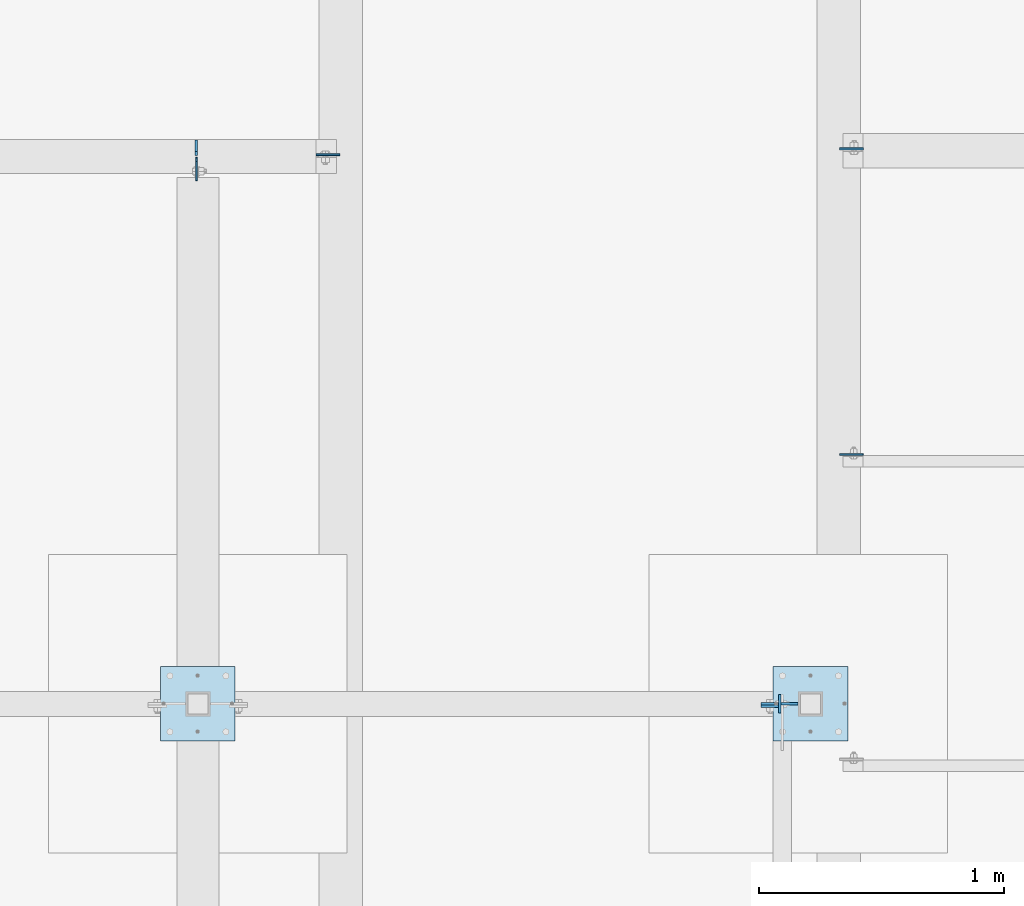
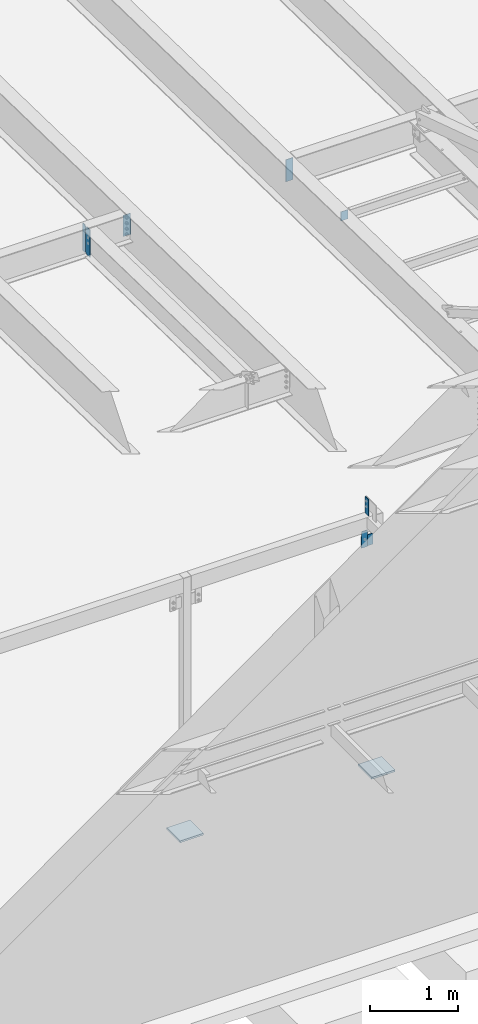
# One storey, part 1473 of 1763: 10 plates, 6 elements without a shape of their own.
"""IFC2X3 building model written with IfcOpenShell, lengths in millimetres."""

import ifcopenshell
import ifcopenshell.guid

model = None  # the IFC model being written
_history = None  # IfcOwnerHistory: only IFC2X3 demands one
_inside = {}  # id of a spatial element -> (the spatial element, [elements in it])
_under = {}  # id of a project, library or spatial element -> (it, [spatial elements below it])
_declared = {}  # id of a project -> (the project, [libraries it declares])
_typed = {}  # id of a type object -> (the type object, [elements of that type])
_made_of = {}  # id of a material, layer set ... -> (it, [elements and type objects made of it])


def new_model(schema):
    """Start an empty IFC model of exactly this schema.

    Asked for "IFC4X3", IfcOpenShell would pick the latest addendum, in which some entities
    have other attributes; the version numbers below select the first issue.
    IFC2X3 requires an IfcOwnerHistory on every rooted entity: one is made here for all.
    """
    global model, _history
    if schema == "IFC4X3":
        model = ifcopenshell.file(schema_version=(4, 3, 0, 0))
    else:
        model = ifcopenshell.file(schema=schema)
    _inside.clear()
    _under.clear()
    _declared.clear()
    _typed.clear()
    _made_of.clear()
    _history = None
    if model.schema == "IFC2X3":
        org = make("IfcOrganization", Name="unknown")
        user = make(
            "IfcPersonAndOrganization",
            ThePerson=make("IfcPerson", FamilyName="unknown"),
            TheOrganization=org,
        )
        app = make(
            "IfcApplication",
            ApplicationDeveloper=org,
            Version="unknown",
            ApplicationFullName="unknown",
            ApplicationIdentifier="unknown",
        )
        _history = make(
            "IfcOwnerHistory",
            OwningUser=user,
            OwningApplication=app,
            ChangeAction="ADDED",
            CreationDate=0,
        )
    return model


def make(cls, **values):
    """One entity of the class cls with the attributes given. An attribute that is None is left unset."""
    return model.create_entity(
        cls, **{name: value for name, value in values.items() if value is not None}
    )


def rooted(cls, **values):
    """An entity with a GlobalId (a new one), such as an element, a storey or a relation."""
    return make(cls, GlobalId=ifcopenshell.guid.new(), OwnerHistory=_history, **values)


def si_unit(unit_type, name, prefix=None):
    """IfcSIUnit, for example si_unit("LENGTHUNIT", "METRE", prefix="MILLI")."""
    return make("IfcSIUnit", UnitType=unit_type, Prefix=prefix, Name=name)


def assignment(units):
    """IfcUnitAssignment: the units of a project."""
    return None if units is None else make("IfcUnitAssignment", Units=units)


def point(xyz):
    """IfcCartesianPoint."""
    return None if xyz is None else make("IfcCartesianPoint", Coordinates=xyz)


def direction(xyz):
    """IfcDirection."""
    return None if xyz is None else make("IfcDirection", DirectionRatios=xyz)


def frame(location, z_axis=None, x_axis=None):
    """IfcAxis2Placement3D, a coordinate frame: its origin and axes. An axis left out is left unset."""
    return make(
        "IfcAxis2Placement3D",
        Location=point(location),
        Axis=direction(z_axis),
        RefDirection=direction(x_axis),
    )


def origin_with_axes():
    """The frame at (0, 0, 0) with the z axis (0, 0, 1) and the x axis (1, 0, 0) written out."""
    return frame((0.0, 0.0, 0.0), z_axis=(0.0, 0.0, 1.0), x_axis=(1.0, 0.0, 0.0))


def place(relative_to, where):
    """IfcLocalPlacement: puts the frame where relative to a parent placement (None: the world)."""
    return make(
        "IfcLocalPlacement", PlacementRelTo=relative_to, RelativePlacement=where
    )


def context(
    kind, dimensions, precision=None, world=None, true_north=None, identifier=None
):
    """IfcGeometricRepresentationContext, for example the 3D "Model" context."""
    return make(
        "IfcGeometricRepresentationContext",
        ContextIdentifier=identifier,
        ContextType=kind,
        CoordinateSpaceDimension=dimensions,
        Precision=precision,
        WorldCoordinateSystem=world,
        TrueNorth=true_north,
    )


def subcontext(parent, identifier, kind, view, scale=None):
    """IfcGeometricRepresentationSubContext, for example "Body" below "Model"."""
    return make(
        "IfcGeometricRepresentationSubContext",
        ContextIdentifier=identifier,
        ContextType=kind,
        ParentContext=parent,
        TargetScale=scale,
        TargetView=view,
    )


def project(units=None, contexts=None):
    """IfcProject with its units and contexts."""
    return rooted(
        "IfcProject",
        Name="project",
        RepresentationContexts=contexts,
        UnitsInContext=assignment(units),
    )


def spatial(cls, under=None, at=None, **own):
    """A site, building, storey or space (cls), placed at a placement, below another one or the project."""
    s = rooted(cls, ObjectPlacement=at, **own)
    if under is not None:
        _under.setdefault(under.id(), (under, []))[1].append(s)
    return s


def faces_of(points, faces, orient=None, outer=None):
    """IfcFace entities. A face is a list of loops; a loop is a list of indices into points, from 0.

    orient and outer hold one flag for each loop. By default every Orientation is true, the
    first loop of a face is its IfcFaceOuterBound and the others are IfcFaceBound.
    """
    made = []
    for i, loops in enumerate(faces):
        bounds = []
        for j, loop in enumerate(loops):
            is_outer = j == 0 if outer is None else outer[i][j]
            bounds.append(
                make(
                    "IfcFaceOuterBound" if is_outer else "IfcFaceBound",
                    Bound=make("IfcPolyLoop", Polygon=[points[k] for k in loop]),
                    Orientation=True if orient is None else orient[i][j],
                )
            )
        made.append(make("IfcFace", Bounds=bounds))
    return made


def faceted_brep(points, faces, orient=None, outer=None, voids=None):
    """IfcFacetedBrep: a solid bounded by flat faces; with voids (closed shells), ...WithVoids."""
    shared = [point(p) for p in points]
    hull = make("IfcClosedShell", CfsFaces=faces_of(shared, faces, orient, outer))
    if voids is None:
        return make("IfcFacetedBrep", Outer=hull)
    return make(
        "IfcFacetedBrepWithVoids",
        Outer=hull,
        Voids=[
            make(cls, CfsFaces=faces_of(shared, fs, o, b)) for cls, fs, o, b in voids
        ],
    )


def shape(context_of_items, identifier, shape_type, items):
    """IfcShapeRepresentation: the items that make up one representation, for example the "Body"."""
    return make(
        "IfcShapeRepresentation",
        ContextOfItems=context_of_items,
        RepresentationIdentifier=identifier,
        RepresentationType=shape_type,
        Items=items,
    )


def material(Name=None, Category=None):
    """IfcMaterial."""
    return make("IfcMaterial", Name=Name, Category=Category)


def made_of(thing, what):
    """Note that an element or type object is made of a material, layer set ...; save() writes the relation."""
    if what is not None:
        _made_of.setdefault(what.id(), (what, []))[1].append(thing)
    return thing


def type_object(cls, material=None, **own):
    """A type object (cls), such as IfcWallType, which elements share."""
    return made_of(rooted(cls, **own), material)


def element(
    cls,
    number,
    at=None,
    inside=None,
    cuts=None,
    type_object=None,
    material=None,
    context=None,
    identifier="Body",
    shape_type=None,
    held_by="IfcProductDefinitionShape",
    body=None,
    shapes=None,
    **own,
):
    """One element of the class cls, such as IfcWall. Its Tag is "e" and its number.

    at: its placement. inside: the storey or other place that contains it. cuts: it is an
    opening in that element (IfcRelVoidsElement). A single representation is given by context,
    identifier, shape_type and body (its items); several are given by shapes. held_by: the class
    of the entity that holds the representations. save() writes the other relations.
    """
    e = rooted(cls, Tag="e%d" % number, ObjectPlacement=at, **own)
    if body is not None:
        shapes = [shape(context, identifier, shape_type, body)]
    if shapes is not None:
        e.Representation = make(held_by, Representations=shapes)
    if inside is not None:
        _inside.setdefault(inside.id(), (inside, []))[1].append(e)
    if cuts is not None:
        rooted(
            "IfcRelVoidsElement", RelatingBuildingElement=cuts, RelatedOpeningElement=e
        )
    if type_object is not None:
        _typed.setdefault(type_object.id(), (type_object, []))[1].append(e)
    return made_of(e, material)


def aggregate(whole, parts):
    """IfcRelAggregates: a whole, such as a stair, and the parts it consists of."""
    return rooted("IfcRelAggregates", RelatingObject=whole, RelatedObjects=parts)


def save(model, path):
    """Write the relations noted so far, then the file.

    IfcRelAggregates (storeys below a building ...), IfcRelContainedInSpatialStructure (elements
    in a storey), IfcRelDefinesByType, IfcRelAssociatesMaterial and IfcRelDeclares: one each for
    every whole, place, type object, material and project.
    """
    for whole, parts in _under.values():
        aggregate(whole, parts)
    for where, things in _inside.values():
        rooted(
            "IfcRelContainedInSpatialStructure",
            RelatedElements=things,
            RelatingStructure=where,
        )
    for kind, things in _typed.values():
        rooted("IfcRelDefinesByType", RelatedObjects=things, RelatingType=kind)
    for what, things in _made_of.values():
        rooted("IfcRelAssociatesMaterial", RelatedObjects=things, RelatingMaterial=what)
    for by, libraries in _declared.values():
        rooted("IfcRelDeclares", RelatingContext=by, RelatedDefinitions=libraries)
    model.write(path)


model = new_model("IFC2X3")

# Units and contexts
model_context = context("Model", 3, precision=1e-05, world=origin_with_axes())
body_context = subcontext(model_context, "Body", "Model", "MODEL_VIEW")
ifc_project = project(units=[si_unit("LENGTHUNIT", "METRE", prefix="MILLI"), si_unit("AREAUNIT", "SQUARE_METRE"), si_unit("VOLUMEUNIT", "CUBIC_METRE"), si_unit("MASSUNIT", "GRAM", prefix="KILO"), si_unit("TIMEUNIT", "SECOND"), si_unit("PLANEANGLEUNIT", "RADIAN"), si_unit("SOLIDANGLEUNIT", "STERADIAN"), si_unit("THERMODYNAMICTEMPERATUREUNIT", "DEGREE_CELSIUS"), si_unit("LUMINOUSINTENSITYUNIT", "LUMEN")], contexts=[model_context])

# Site, building, storey
site_placement = place(None, origin_with_axes())
site = spatial("IfcSite", under=ifc_project, at=site_placement, CompositionType="ELEMENT")
building_placement = place(site_placement, origin_with_axes())
building = spatial("IfcBuilding", under=site, at=building_placement, Name="Undefined", CompositionType="ELEMENT")
storey_placement = place(building_placement, origin_with_axes())
storey = spatial("IfcBuildingStorey", under=building, at=storey_placement, Name="Undefined", CompositionType="ELEMENT", Elevation=0.0)

# Assembly, plates
assembly_1_placement = place(storey_placement, origin_with_axes())
assembly_1 = element("IfcElementAssembly", 1, at=assembly_1_placement, inside=storey, Name="BEAM", AssemblyPlace="NOTDEFINED", PredefinedType="RIGID_FRAME")
ifc_material = material(Name="STEEL/A36")
plate_type_1 = type_object("IfcPlateType", PredefinedType="NOTDEFINED")
plate_1_placement = place(assembly_1_placement, frame((-49642.1836843334, -10960.099958583, 8623.3221108939), z_axis=(0.0, 0.0, 1.0), x_axis=(0.0, -1.0, 0.0)))
plate_1 = element("IfcPlate", 2, at=plate_1_placement, type_object=plate_type_1, material=ifc_material, Name="PLATE", context=body_context, shape_type="Brep", body=[
    faceted_brep([(0.0, -4.76249999999982, 0.0), (-2.83762346953154e-10, -4.7624999996915, 228.600006103516), (-2.83762346953154e-10, 4.76250000028813, 228.600006103517), (0.0, 4.76249999999982, 0.0), (76.1999969480166, -4.76249999961874, 228.600006103516), (76.1999969480166, 4.76250000036089, 228.600006103517), (76.1999969482931, -4.76249999991705, 0.0), (76.1999969482931, 4.76250000006257, 1.81898940354586e-12)], [[[0, 1, 2, 3]], [[1, 4, 5, 2]], [[4, 6, 7, 5]], [[6, 0, 3, 7]], [[5, 7, 3, 2]], [[6, 4, 1, 0]]]),
])
plate_2_placement = place(assembly_1_placement, frame((-49643.7372858423, -11007.7249689336, 8420.09999389775), z_axis=(0.0, 0.0, -1.0), x_axis=(-1.0, 0.0, 0.0)))
plate_2 = element("IfcPlate", 3, at=plate_2_placement, type_object=plate_type_1, material=ifc_material, Name="PLATE", context=body_context, shape_type="Brep", body=[
    faceted_brep([(0.0, -4.76249999999982, 0.0), (-2.83762346953154e-10, -4.7624999996915, 228.600006103516), (-2.83762346953154e-10, 4.76250000028813, 228.600006103517), (0.0, 4.76249999999982, 0.0), (76.1999969480166, -4.76249999961874, 228.600006103516), (76.1999969480166, 4.76250000036089, 228.600006103517), (76.1999969482931, -4.76249999991705, 0.0), (76.1999969482931, 4.76250000006257, 1.81898940354586e-12)], [[[0, 1, 2, 3]], [[1, 4, 5, 2]], [[4, 6, 7, 5]], [[6, 0, 3, 7]], [[5, 7, 3, 2]], [[6, 4, 1, 0]]]),
])
aggregate(assembly_1, [plate_1, plate_2])

# Assembly, plate
assembly_2_placement = place(storey_placement, origin_with_axes())
assembly_2 = element("IfcElementAssembly", 4, at=assembly_2_placement, inside=storey, Name="COLUMN", AssemblyPlace="NOTDEFINED", PredefinedType="RIGID_FRAME")
plate_type_2 = type_object("IfcPlateType", PredefinedType="NOTDEFINED")
plate_3_placement = place(assembly_2_placement, frame((-49719.9372827524, -10998.1999697475, 8191.49998779423), z_axis=(0.0, 0.0, 1.0), x_axis=(1.0, 0.0, 0.0)))
plate_3 = element("IfcPlate", 5, at=plate_3_placement, type_object=plate_type_2, material=ifc_material, Name="PLATE", context=body_context, shape_type="Brep", body=[
    faceted_brep([(0.0, -4.76249999999982, 0.0), (-3.05175672110636e-06, -4.7625000002663, 152.399993896484), (-3.05175490211695e-06, 4.76249999972788, 152.399993896484), (0.0, 4.76249999999982, 0.0), (152.400009155272, -4.76249999975698, 152.399993896484), (152.400009155273, 4.76250000024447, 152.399993896484), (152.400009155272, -4.76249999948777, 5.45696821063757e-12), (152.400009155273, 4.76250000051368, 3.63797880709171e-12)], [[[0, 1, 2, 3]], [[1, 4, 5, 2]], [[4, 6, 7, 5]], [[6, 0, 3, 7]], [[5, 7, 3, 2]], [[6, 4, 1, 0]]]),
])

assembly_3_placement = place(storey_placement, origin_with_axes())
assembly_3 = element("IfcElementAssembly", 6, at=assembly_3_placement, inside=storey, Name="BEAM", AssemblyPlace="NOTDEFINED", PredefinedType="RIGID_FRAME")
plate_type_3 = type_object("IfcPlateType", PredefinedType="NOTDEFINED")
plate_4_placement = place(assembly_3_placement, frame((-49397.6747736984, -9980.20652046014, 12101.2660879204), z_axis=(1.0, 0.0, 0.0), x_axis=(0.0, 0.0, -1.0)))
plate_4 = element("IfcPlate", 7, at=plate_4_placement, type_object=plate_type_3, material=ifc_material, Name="PLATE", context=body_context, shape_type="Brep", body=[
    faceted_brep([(1.81898940354586e-12, -3.17500000000291, 0.0), (0.0, -3.17499999999927, 95.25), (0.0, 3.17499999999927, 95.25), (-1.81898940354586e-12, 3.17499999997381, 0.0), (127.0, -3.17499999999927, 95.25), (127.0, 3.17499999999927, 95.25), (127.0, -3.17499999999927, 0.0), (127.0, 3.17499999999927, 0.0)], [[[0, 1, 2, 3]], [[1, 4, 5, 2]], [[4, 6, 7, 5]], [[6, 0, 3, 7]], [[5, 7, 3, 2]], [[6, 4, 1, 0]]]),
])

assembly_4_placement = place(storey_placement, origin_with_axes())
assembly_4 = element("IfcElementAssembly", 8, at=assembly_4_placement, inside=storey, Name="BEAM", AssemblyPlace="NOTDEFINED", PredefinedType="RIGID_FRAME")
plate_5_placement = place(assembly_4_placement, frame((-52024.987273746, -8766.2304259654, 11710.6291231283), z_axis=(0.0, 0.0, 1.0), x_axis=(0.0, -1.0, 0.0)))
plate_5 = element("IfcPlate", 9, at=plate_5_placement, type_object=plate_type_3, material=ifc_material, Name="PLATE", context=body_context, shape_type="Brep", body=[
    faceted_brep([(0.0, -3.17500000000291, 17.4624996185303), (0.0, -3.17500000000291, 363.53750038147), (0.0, 3.17500000000291, 363.53750038147), (0.0, 3.17500000000291, 17.4624996185303), (17.4624996185303, -3.17500000000291, 381.0), (17.4624996185303, 3.17500000000291, 381.0), (95.25, -3.17500000000291, 381.0), (95.25, 3.17500000000291, 381.0), (95.25, -3.17500000000291, 0.0), (95.25, 3.17500000000291, 0.0), (17.4624996185303, -3.17500000000291, 0.0), (17.4624996185303, 3.17500000000291, 0.0)], [[[0, 1, 2, 3]], [[1, 4, 5, 2]], [[4, 6, 7, 5]], [[6, 8, 9, 7]], [[8, 10, 11, 9]], [[10, 0, 3, 11]], [[5, 7, 9, 11, 3, 2]], [[10, 8, 6, 4, 1, 0]]]),
])

# Plate
plate_type_4 = type_object("IfcPlateType", PredefinedType="NOTDEFINED")
plate_6_placement = place(assembly_3_placement, frame((-49397.6747736984, -8732.03523577183, 12062.5549693304), z_axis=(1.0, 0.0, 0.0), x_axis=(0.0, 0.0, -1.0)))
plate_6 = element("IfcPlate", 10, at=plate_6_placement, type_object=plate_type_4, material=ifc_material, Name="PLATE", context=body_context, shape_type="Brep", body=[
    faceted_brep([(0.0, -3.96900000000096, 0.0), (0.0, -3.96899999999914, 96.8375015258789), (0.0, 3.96899999999914, 96.8375015258789), (0.0, 3.96900000000096, 0.0), (304.799987792969, -3.96899999999914, 96.8375015258789), (304.799987792969, 3.96899999999914, 96.8375015258789), (304.799987792969, -3.96900000000096, -3.63797880709171e-11), (304.799987792969, 3.96900000000096, -3.63797880709171e-11)], [[[0, 1, 2, 3]], [[1, 4, 5, 2]], [[4, 6, 7, 5]], [[6, 0, 3, 7]], [[5, 7, 3, 2]], [[6, 4, 1, 0]]]),
])

aggregate(assembly_3, [plate_4, plate_6])

# Assembly, plate
assembly_5_placement = place(storey_placement, origin_with_axes())
assembly_5 = element("IfcElementAssembly", 11, at=assembly_5_placement, inside=storey, Name="BEAM", AssemblyPlace="NOTDEFINED", PredefinedType="RIGID_FRAME")
plate_7_placement = place(assembly_5_placement, frame((-51439.1997736983, -8755.91142595737, 12056.7041231251), z_axis=(-1.0, 0.0, 0.0), x_axis=(0.0, 0.0, -1.0)))
plate_7 = element("IfcPlate", 12, at=plate_7_placement, type_object=plate_type_4, material=ifc_material, Name="PLATE", context=body_context, shape_type="Brep", body=[
    faceted_brep([(0.0, -3.96900000000096, 0.0), (0.0, -3.96899999999914, 96.8375015258789), (0.0, 3.96899999999914, 96.8375015258789), (0.0, 3.96900000000096, 0.0), (292.100006103516, -3.96899999999914, 96.8375015258789), (292.100006103516, 3.96899999999914, 96.8375015258789), (292.100006103516, -3.96899999999914, 0.0), (292.100006103516, 3.96899999999914, 0.0)], [[[0, 1, 2, 3]], [[1, 4, 5, 2]], [[4, 6, 7, 5]], [[6, 0, 3, 7]], [[5, 7, 3, 2]], [[6, 4, 1, 0]]]),
])
aggregate(assembly_5, [plate_7])

# Plate
plate_type_5 = type_object("IfcPlateType", PredefinedType="NOTDEFINED")
plate_8_placement = place(assembly_4_placement, frame((-52024.9877736144, -8759.88042596541, 11710.6291231283), z_axis=(0.0, 0.0, 1.0), x_axis=(0.0, 1.0, 0.0)))
plate_8 = element("IfcPlate", 13, at=plate_8_placement, type_object=plate_type_5, material=ifc_material, Name="PLATE", context=body_context, shape_type="Brep", body=[
    faceted_brep([(0.0, -4.76249999999709, 17.4624996185303), (0.0, -4.76249999999709, 363.53750038147), (0.0, 4.76249999999709, 363.53750038147), (0.0, 4.76249999999709, 17.4624996185303), (17.4624996185303, -4.76249999999709, 381.0), (17.4624996185303, 4.76249999999709, 381.0), (63.5, -4.76249999999709, 381.0), (63.5, 4.76249999999709, 381.0), (63.4999999999964, -4.76250000017171, 0.0), (63.5000000000036, 4.76249999982974, 0.0), (17.4624996185303, -4.76249999999709, 0.0), (17.4624996185303, 4.76249999999709, 0.0)], [[[0, 1, 2, 3]], [[1, 4, 5, 2]], [[4, 6, 7, 5]], [[6, 8, 9, 7]], [[8, 10, 11, 9]], [[10, 0, 3, 11]], [[5, 7, 9, 11, 3, 2]], [[10, 8, 6, 4, 1, 0]]]),
])

aggregate(assembly_4, [plate_8, plate_5])

plate_type_6 = type_object("IfcPlateType", PredefinedType="NOTDEFINED")
plate_9_placement = place(assembly_2_placement, frame((-49669.1540133289, -10845.7999679201, 5080.0), z_axis=(1.0, 0.0, 0.0), x_axis=(0.0, -1.0, 0.0)))
plate_9 = element("IfcPlate", 14, at=plate_9_placement, type_object=plate_type_6, material=ifc_material, Name="PLATE", context=body_context, shape_type="Brep", body=[
    faceted_brep([(0.0, -12.6999999999971, -1.81898940354586e-12), (0.0, -12.6999999999998, 304.799987792969), (0.0, 12.6999999999998, 304.799987792969), (0.0, 12.6999999999971, -1.81898940354586e-12), (304.799987792969, -12.6999999999998, 304.799987792969), (304.799987792969, 12.6999999999998, 304.799987792969), (304.799987792969, -12.6999999999998, 0.0), (304.799987792969, 12.6999999999998, 0.0)], [[[0, 1, 2, 3]], [[1, 4, 5, 2]], [[4, 6, 7, 5]], [[6, 0, 3, 7]], [[5, 7, 3, 2]], [[6, 4, 1, 0]]]),
])

aggregate(assembly_2, [plate_3, plate_9])

# Assembly, plate
assembly_6_placement = place(storey_placement, origin_with_axes())
assembly_6 = element("IfcElementAssembly", 15, at=assembly_6_placement, inside=storey, Name="COLUMN", AssemblyPlace="NOTDEFINED", PredefinedType="RIGID_FRAME")
plate_10_placement = place(assembly_6_placement, frame((-52171.0372736983, -10845.7999679201, 5080.0), z_axis=(1.0, 0.0, 0.0), x_axis=(0.0, -1.0, 0.0)))
plate_10 = element("IfcPlate", 16, at=plate_10_placement, type_object=plate_type_6, material=ifc_material, Name="PLATE", context=body_context, shape_type="Brep", body=[
    faceted_brep([(0.0, -12.6999999999971, -1.81898940354586e-12), (0.0, -12.6999999999998, 304.799987792969), (0.0, 12.6999999999998, 304.799987792969), (0.0, 12.6999999999971, -1.81898940354586e-12), (304.799987792969, -12.6999999999998, 304.799987792969), (304.799987792969, 12.6999999999998, 304.799987792969), (304.799987792969, -12.6999999999998, 0.0), (304.799987792969, 12.6999999999998, 0.0)], [[[0, 1, 2, 3]], [[1, 4, 5, 2]], [[4, 6, 7, 5]], [[6, 0, 3, 7]], [[5, 7, 3, 2]], [[6, 4, 1, 0]]]),
])
aggregate(assembly_6, [plate_10])

save(model, "model.ifc")
